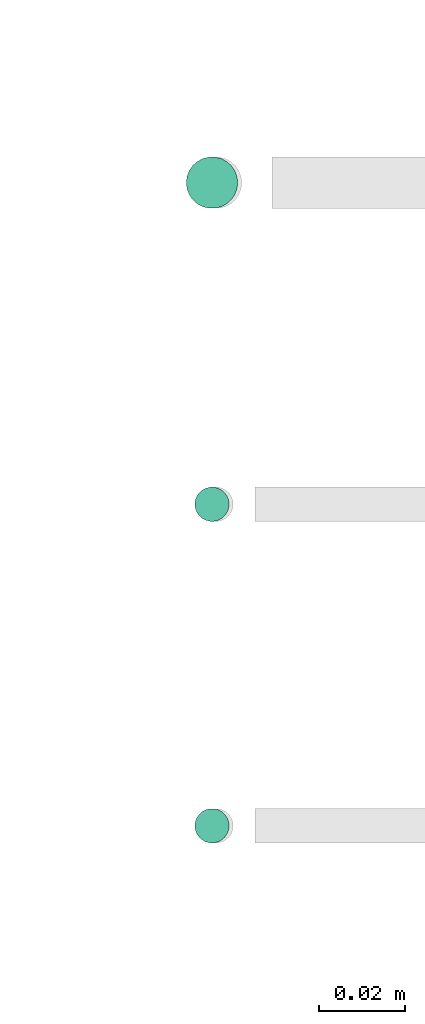
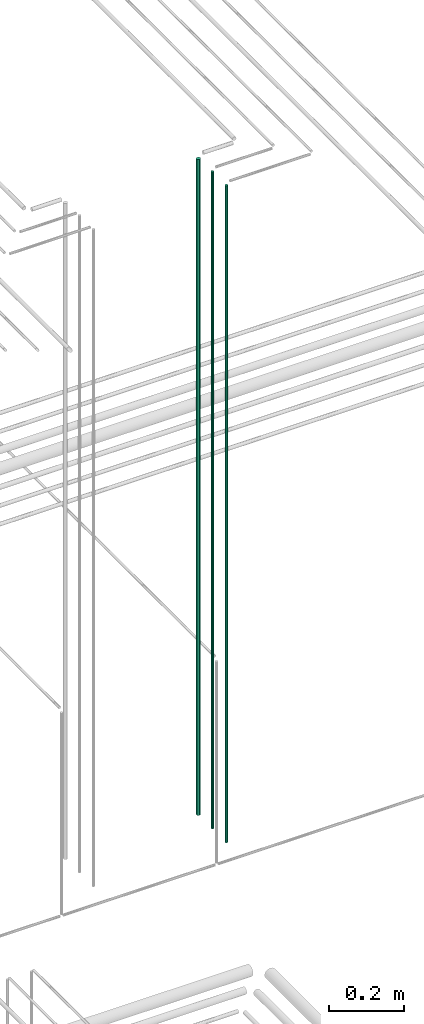
# One storey, part 62 of 331: 3 flow segments.
"""IFC2X3 building model written with IfcOpenShell, lengths in millimetres."""

from ifc_helpers import new_model, entity, si_unit, converted_unit, derived_unit, direction, frame, frame_2d, origin, origin_2d_with_axis, place, context, subcontext, project, spatial, circle, extrude, type_object, element, save


model = new_model("IFC2X3")

# Units and contexts
model_context = context("Model", 3, precision=0.01, world=origin(), true_north=direction((6.12303176911189e-17, 1.0)))
body_context = subcontext(model_context, "Body", "Model", "MODEL_VIEW")
ifc_project = project(units=[si_unit("LENGTHUNIT", "METRE", prefix="MILLI"), si_unit("AREAUNIT", "SQUARE_METRE"), si_unit("VOLUMEUNIT", "CUBIC_METRE"), converted_unit("PLANEANGLEUNIT", "DEGREE", entity("IfcRatioMeasure", 0.0174532925199433), si_unit("PLANEANGLEUNIT", "RADIAN"), dimensions=[0, 0, 0, 0, 0, 0, 0]), si_unit("MASSUNIT", "GRAM", prefix="KILO"), derived_unit("MASSDENSITYUNIT", [(si_unit("MASSUNIT", "GRAM", prefix="KILO"), 1), (si_unit("LENGTHUNIT", "METRE"), -3)]), derived_unit("MOMENTOFINERTIAUNIT", [(si_unit("LENGTHUNIT", "METRE"), 4)]), si_unit("TIMEUNIT", "SECOND"), si_unit("FREQUENCYUNIT", "HERTZ"), si_unit("THERMODYNAMICTEMPERATUREUNIT", "DEGREE_CELSIUS"), derived_unit("THERMALTRANSMITTANCEUNIT", [(si_unit("MASSUNIT", "GRAM", prefix="KILO"), 1), (si_unit("THERMODYNAMICTEMPERATUREUNIT", "KELVIN"), -1), (si_unit("TIMEUNIT", "SECOND"), -3)]), derived_unit("VOLUMETRICFLOWRATEUNIT", [(si_unit("LENGTHUNIT", "METRE"), 3), (si_unit("TIMEUNIT", "SECOND"), -1)]), derived_unit("MASSFLOWRATEUNIT", [(si_unit("MASSUNIT", "GRAM", prefix="KILO"), 1), (si_unit("TIMEUNIT", "SECOND"), -1)]), derived_unit("ROTATIONALFREQUENCYUNIT", [(si_unit("TIMEUNIT", "SECOND"), -1)]), si_unit("ELECTRICCURRENTUNIT", "AMPERE"), si_unit("ELECTRICVOLTAGEUNIT", "VOLT"), si_unit("POWERUNIT", "WATT"), si_unit("FORCEUNIT", "NEWTON", prefix="KILO"), si_unit("ILLUMINANCEUNIT", "LUX"), si_unit("LUMINOUSFLUXUNIT", "LUMEN"), si_unit("LUMINOUSINTENSITYUNIT", "CANDELA"), derived_unit("USERDEFINED", [(si_unit("MASSUNIT", "GRAM", prefix="KILO"), -1), (si_unit("LENGTHUNIT", "METRE"), -2), (si_unit("TIMEUNIT", "SECOND"), 3), (si_unit("LUMINOUSFLUXUNIT", "LUMEN"), 1)]), derived_unit("LINEARVELOCITYUNIT", [(si_unit("LENGTHUNIT", "METRE"), 1), (si_unit("TIMEUNIT", "SECOND"), -1)]), si_unit("PRESSUREUNIT", "PASCAL"), derived_unit("USERDEFINED", [(si_unit("LENGTHUNIT", "METRE"), -2), (si_unit("MASSUNIT", "GRAM", prefix="KILO"), 1), (si_unit("TIMEUNIT", "SECOND"), -2)]), derived_unit("LINEARFORCEUNIT", [(si_unit("MASSUNIT", "GRAM", prefix="KILO"), 1), (si_unit("LENGTHUNIT", "METRE"), 1), (si_unit("TIMEUNIT", "SECOND"), -2), (si_unit("LENGTHUNIT", "METRE"), -1)]), derived_unit("PLANARFORCEUNIT", [(si_unit("MASSUNIT", "GRAM", prefix="KILO"), 1), (si_unit("LENGTHUNIT", "METRE"), 1), (si_unit("TIMEUNIT", "SECOND"), -2), (si_unit("LENGTHUNIT", "METRE"), -2)])], contexts=[model_context])

# Site, building, storey
site_placement = place(None, frame((0.0, -0.00077364408347762, 0.0)))
site = spatial("IfcSite", under=ifc_project, at=site_placement, CompositionType="ELEMENT")
building_placement = place(site_placement, origin())
building = spatial("IfcBuilding", under=site, at=building_placement, CompositionType="ELEMENT")
storey_placement = place(building_placement, origin())
storey = spatial("IfcBuildingStorey", under=building, at=storey_placement, CompositionType="ELEMENT", Elevation=0.0)

# Flow segments
pipe_segment_type = type_object("IfcPipeSegmentType", PredefinedType="NOTDEFINED")
flow_segment_placement = place(storey_placement, frame((53568.1864417171, 3883.89349484376, 16890.0)))
element("IfcFlowSegment", 1, at=flow_segment_placement, inside=storey, type_object=pipe_segment_type, context=body_context, shape_type="SweptSolid", body=[
    extrude(circle(Radius=6.0, at=frame_2d((0.0, 5.41433564649196e-13), x_axis=(1.0, 0.0))), frame((7.59527223591454, 7.59527223591562, 0.0)), (0.0, 0.0, 1.0), 2146.0),
])
for number, where in (
    (2, (53570.1864417171, 3735.89349484376, 16890.0)),
    (3, (53570.1864417171, 3810.89349484376, 16890.0)),
):
    element("IfcFlowSegment", number, at=place(storey_placement, frame(where)), inside=storey, type_object=pipe_segment_type, context=body_context, shape_type="SweptSolid", body=[
        extrude(circle(Radius=4.0, at=origin_2d_with_axis()), frame((5.59527223591499, 5.59527223591607, 0.0)), (0.0, 0.0, 1.0), 2150.00000000001),
    ])

save(model, "model.ifc")
